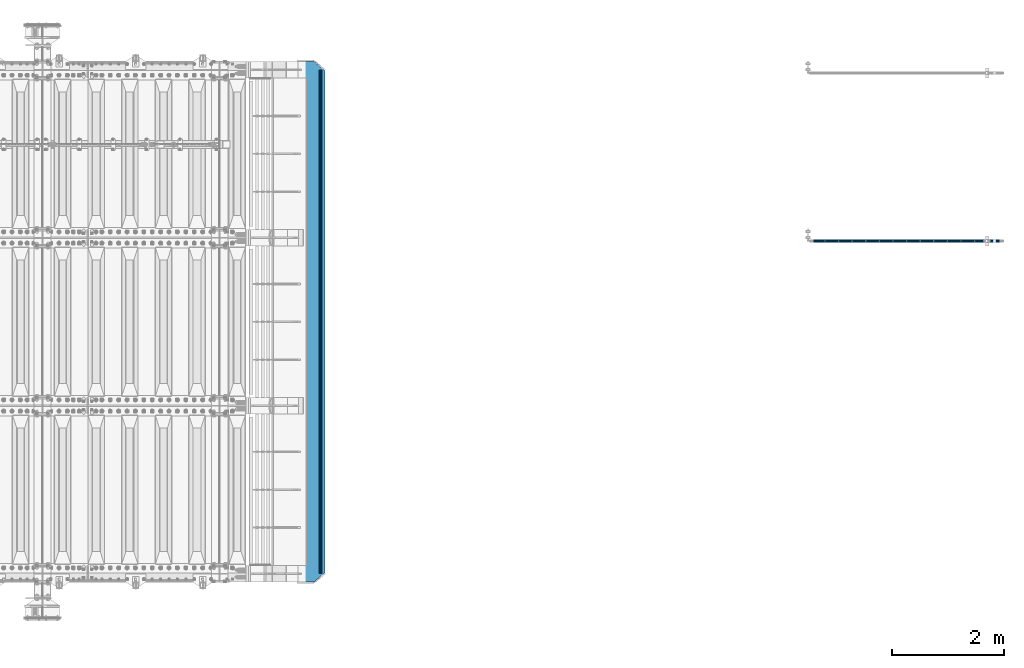
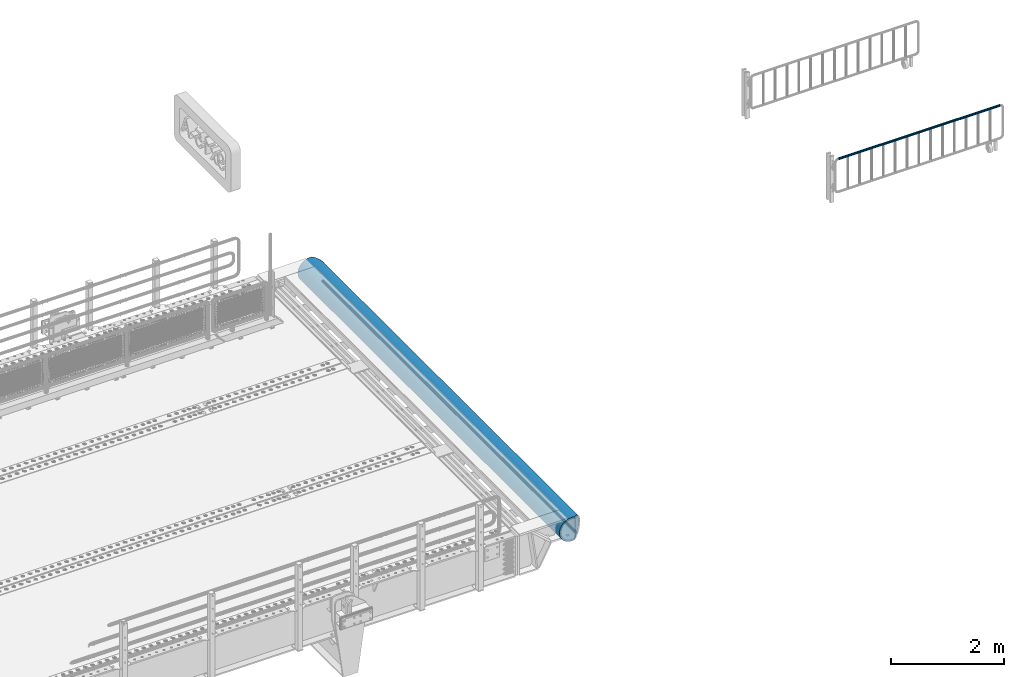
# One storey, part 119 of 219: 3 beams.
"""IFC2X3 building model written with IfcOpenShell, lengths in millimetres."""

from ifc_helpers import new_model, si_unit, frame, origin_with_axes, place, context, subcontext, project, spatial, faceted_brep, material, type_object, element, save


model = new_model("IFC2X3")

# Units and contexts
model_context = context("Model", 3, precision=1e-05, world=origin_with_axes())
body_context = subcontext(model_context, "Body", "Model", "MODEL_VIEW")
ifc_project = project(units=[si_unit("LENGTHUNIT", "METRE", prefix="MILLI"), si_unit("AREAUNIT", "SQUARE_METRE"), si_unit("VOLUMEUNIT", "CUBIC_METRE"), si_unit("MASSUNIT", "GRAM", prefix="KILO"), si_unit("TIMEUNIT", "SECOND"), si_unit("PLANEANGLEUNIT", "RADIAN"), si_unit("SOLIDANGLEUNIT", "STERADIAN"), si_unit("THERMODYNAMICTEMPERATUREUNIT", "DEGREE_CELSIUS"), si_unit("LUMINOUSINTENSITYUNIT", "LUMEN")], contexts=[model_context])

# Site, building, storey
site_placement = place(None, origin_with_axes())
site = spatial("IfcSite", under=ifc_project, at=site_placement, CompositionType="ELEMENT")
building_placement = place(site_placement, origin_with_axes())
building = spatial("IfcBuilding", under=site, at=building_placement, Name="Standard", CompositionType="ELEMENT")
storey_placement = place(building_placement, origin_with_axes())
storey = spatial("IfcBuildingStorey", under=building, at=storey_placement, Name="Undefined", CompositionType="ELEMENT", Elevation=0.0)

# Beams
ifc_material_1 = material()
beam_type_1 = type_object("IfcBeamType", PredefinedType="NOTDEFINED")
beam_1_placement = place(storey_placement, frame((24165.2460172356, 29941.8539999962, 935.350006544462), z_axis=(0.0, 0.0, 1.0), x_axis=(1.0, 0.0, 0.0)))
element("IfcBeam", 1, at=beam_1_placement, inside=storey, type_object=beam_type_1, material=ifc_material_1, context=body_context, shape_type="Brep", body=[
    faceted_brep([(0.0, -20.5499999999993, 0.0), (0.0, -17.7968220477705, 10.2750000000015), (3317.7, -17.7968220477705, 10.275), (3317.7, -20.5499999999993, 0.0), (0.0, -10.2750000000015, 17.7968220477705), (3317.7, -10.2750000000015, 17.7968220477702), (0.0, 0.0, 20.5499999999993), (3317.7, 0.0, 20.55), (0.0, 10.2750000000015, 17.7968220477705), (3317.7, 10.2750000000015, 17.7968220477702), (0.0, 17.7968220477705, 10.2750000000015), (3317.7, 17.7968220477705, 10.275), (0.0, 20.5499999999993, 0.0), (3317.7, 20.5499999999993, 0.0), (0.0, 17.7968220477705, -10.2750000000015), (3317.7, 17.7968220477705, -10.275), (0.0, 10.2750000000015, -17.7968220477705), (3317.7, 10.2750000000015, -17.7968220477702), (0.0, 0.0, -20.5499999999993), (3317.7, 0.0, -20.55), (0.0, -10.2750000000015, -17.7968220477705), (3317.7, -10.2750000000015, -17.7968220477702), (0.0, -17.7968220477705, -10.2750000000015), (3317.7, -17.7968220477705, -10.275), (0.0, -24.1500000000015, 0.0), (0.0, -20.9145135013932, -12.0750000000007), (3317.7, -20.9145135013932, -12.075), (3317.7, -24.1500000000015, 0.0), (0.0, -12.0750000000007, -20.9145135013932), (3317.7, -12.0750000000007, -20.9145135013943), (0.0, 0.0, -24.1500000000015), (3317.7, 0.0, -24.15), (0.0, 12.0750000000007, -20.9145135013932), (3317.7, 12.0750000000007, -20.9145135013941), (0.0, 20.9145135013932, -12.0750000000007), (3317.7, 20.9145135013932, -12.075), (0.0, 24.1500000000015, 0.0), (3317.7, 24.1500000000015, 0.0), (0.0, 20.9145135013932, 12.0750000000007), (3317.7, 20.9145135013932, 12.075), (0.0, 12.0750000000007, 20.9145135013932), (3317.7, 12.0750000000007, 20.9145135013941), (0.0, 0.0, 24.1500000000015), (3317.7, 0.0, 24.15), (0.0, -12.0750000000007, 20.9145135013932), (3317.7, -12.0750000000007, 20.9145135013941), (0.0, -20.9145135013932, 12.0750000000007), (3317.7, -20.9145135013932, 12.075)], [[[0, 1, 2, 3]], [[1, 4, 5, 2]], [[4, 6, 7, 5]], [[6, 8, 9, 7]], [[8, 10, 11, 9]], [[10, 12, 13, 11]], [[12, 14, 15, 13]], [[14, 16, 17, 15]], [[16, 18, 19, 17]], [[18, 20, 21, 19]], [[20, 22, 23, 21]], [[22, 0, 3, 23]], [[24, 25, 26, 27]], [[25, 28, 29, 26]], [[28, 30, 31, 29]], [[30, 32, 33, 31]], [[32, 34, 35, 33]], [[34, 36, 37, 35]], [[36, 38, 39, 37]], [[38, 40, 41, 39]], [[40, 42, 43, 41]], [[42, 44, 45, 43]], [[44, 46, 47, 45]], [[46, 24, 27, 47]], [[29, 31, 33, 35, 37, 39, 41, 43, 45, 47, 27, 26], [5, 7, 9, 11, 13, 15, 17, 19, 21, 23, 3, 2]], [[46, 44, 42, 40, 38, 36, 34, 32, 30, 28, 25, 24], [22, 20, 18, 16, 14, 12, 10, 8, 6, 4, 1, 0]]]),
])
ifc_material_2 = material(Name="STEEL/S355N")
beam_type_2 = type_object("IfcBeamType", PredefinedType="NOTDEFINED")
beam_2_placement = place(storey_placement, frame((15182.9988298906, 33150.0, -254.000000000001), z_axis=(0.0, 0.0, 1.0), x_axis=(0.0, -1.0, 0.0)))
element("IfcBeam", 2, at=beam_2_placement, inside=storey, type_object=beam_type_2, material=ifc_material_2, context=body_context, shape_type="Brep", body=[
    faceted_brep([(6132.32233047034, -17.6739734137791, -220.609028125962), (6132.32233047034, -17.6739734137791, -252.609028125963), (6126.90301168722, -9.56338969324315, -253.247344908113), (6126.90301168722, -9.56338969324315, -221.247344908112), (6140.43291419087, -23.0932921968979, -220.182518487904), (6140.43291419087, -23.0932921968979, -252.182518487904), (6150.0, -24.9963038841161, -220.032748220013), (6150.0, -24.9963038841161, -252.032748220013), (6159.56708580913, -23.0932921968979, -220.182518487904), (6159.56708580913, -23.0932921968979, -252.182518487904), (6167.67766952966, -17.6739734137791, -220.609028125962), (6167.67766952966, -17.6739734137791, -252.609028125963), (6173.09698831278, -9.56338969324315, -221.247344908112), (6173.09698831278, -9.56338969324315, -253.247344908113), (6175.0, 0.0, -222.0), (6175.0, 0.0, -254.0), (6173.09698831278, 9.57078192501103, -221.246763126855), (6173.09698831278, 9.57078192501103, -253.246763126856), (6167.67766952966, 17.681365645547, -220.608446344705), (6167.67766952966, 17.681365645547, -252.608446344706), (6159.56708580913, 23.1006844286658, -220.181936706647), (6159.56708580913, 23.1006844286658, -252.181936706648), (6150.0, 25.0036961158839, -220.032166438756), (6150.0, 25.0036961158839, -252.032166438756), (6140.43291419087, 23.1006844286658, -220.181936706647), (6140.43291419087, 23.1006844286658, -252.181936706648), (6132.32233047034, 17.681365645547, -220.608446344705), (6132.32233047034, 17.681365645547, -252.608446344706), (6126.90301168722, 9.57078192501103, -221.246763126855), (6126.90301168722, 9.57078192501103, -253.246763126856), (6125.0, 0.0, -222.0), (6125.0, 0.0, -254.0), (4632.32233047034, -17.6739734137755, -220.609028125963), (4632.32233047034, -17.6739734137755, -252.609028125962), (4626.90301168722, -9.56338969323951, -253.247344908112), (4626.90301168722, -9.56338969323951, -221.247344908113), (4640.43291419087, -23.0932921968943, -220.182518487905), (4640.43291419087, -23.0932921968943, -252.182518487904), (4650.0, -24.9963038841124, -220.032748220013), (4650.0, -24.9963038841124, -252.032748220013), (4659.56708580913, -23.0932921968943, -220.182518487905), (4659.56708580913, -23.0932921968943, -252.182518487904), (4667.67766952966, -17.6739734137755, -220.609028125963), (4667.67766952966, -17.6739734137755, -252.609028125962), (4673.09698831278, -9.56338969323951, -221.247344908113), (4673.09698831278, -9.56338969323951, -253.247344908112), (4675.0, 0.0, -222.0), (4675.0, 0.0, -254.0), (4673.09698831278, 9.57078192501467, -221.246763126855), (4673.09698831278, 9.57078192501467, -253.246763126856), (4667.67766952966, 17.6813656455506, -220.608446344705), (4667.67766952966, 17.6813656455506, -252.608446344705), (4659.56708580913, 23.1006844286694, -220.181936706647), (4659.56708580913, 23.1006844286694, -252.181936706647), (4650.0, 25.0036961158876, -220.032166438756), (4650.0, 25.0036961158876, -252.032166438756), (4640.43291419087, 23.1006844286694, -220.181936706647), (4640.43291419087, 23.1006844286694, -252.181936706647), (4632.32233047034, 17.6813656455506, -220.608446344705), (4632.32233047034, 17.6813656455506, -252.608446344705), (4626.90301168722, 9.57078192501467, -221.246763126855), (4626.90301168722, 9.57078192501467, -253.246763126856), (4625.0, 0.0, -222.0), (4625.0, 0.0, -254.0), (3132.32233047034, -17.6776695296594, -220.608737235334), (3132.32233047034, -17.6776695296594, -252.608737235334), (3126.90301168722, -9.56708580912346, -253.247054017484), (3126.90301168722, -9.56708580912346, -221.247054017484), (3140.43291419087, -23.0969883127782, -220.182227597276), (3140.43291419087, -23.0969883127782, -252.182227597276), (3150.0, -24.9999999999964, -220.032457329385), (3150.0, -24.9999999999964, -252.032457329385), (3159.56708580913, -23.0969883127782, -220.182227597276), (3159.56708580913, -23.0969883127782, -252.182227597276), (3167.67766952966, -17.6776695296594, -220.608737235334), (3167.67766952966, -17.6776695296594, -252.608737235334), (3173.09698831278, -9.56708580912346, -221.247054017484), (3173.09698831278, -9.56708580912346, -253.247054017484), (3175.0, 0.0, -222.0), (3175.0, 0.0, -254.0), (3173.09698831278, 9.56708580913073, -221.247054017484), (3173.09698831278, 9.56708580913073, -253.247054017484), (3167.67766952966, 17.6776695296667, -220.608737235334), (3167.67766952966, 17.6776695296667, -252.608737235334), (3159.56708580913, 23.0969883127855, -220.182227597275), (3159.56708580913, 23.0969883127855, -252.182227597276), (3150.0, 25.0000000000036, -220.032457329384), (3150.0, 25.0000000000036, -252.032457329384), (3140.43291419087, 23.0969883127855, -220.182227597275), (3140.43291419087, 23.0969883127855, -252.182227597276), (3132.32233047034, 17.6776695296667, -220.608737235334), (3132.32233047034, 17.6776695296667, -252.608737235334), (3126.90301168722, 9.56708580913073, -221.247054017484), (3126.90301168722, 9.56708580913073, -253.247054017484), (3125.0, 0.0, -222.0), (3125.0, 0.0, -254.0), (1632.32233047034, -17.6776695296594, -220.608737235334), (1632.32233047034, -17.6776695296594, -252.608737235334), (1626.90301168722, -9.56708580912346, -253.247054017484), (1626.90301168722, -9.56708580912346, -221.247054017484), (1640.43291419087, -23.0969883127782, -220.182227597276), (1640.43291419087, -23.0969883127782, -252.182227597276), (1650.0, -24.9999999999964, -220.032457329385), (1650.0, -24.9999999999964, -252.032457329385), (1659.56708580913, -23.0969883127782, -220.182227597276), (1659.56708580913, -23.0969883127782, -252.182227597276), (1667.67766952966, -17.6776695296594, -220.608737235334), (1667.67766952966, -17.6776695296594, -252.608737235334), (1673.09698831278, -9.56708580912346, -221.247054017484), (1673.09698831278, -9.56708580912346, -253.247054017484), (1675.0, 0.0, -222.0), (1675.0, 0.0, -254.0), (1673.09698831278, 9.56708580913073, -221.247054017483), (1673.09698831278, 9.56708580913073, -253.247054017484), (1667.67766952966, 17.6776695296667, -220.608737235333), (1667.67766952966, 17.6776695296667, -252.608737235334), (1659.56708580913, 23.0969883127855, -220.182227597275), (1659.56708580913, 23.0969883127855, -252.182227597276), (1650.0, 25.0000000000036, -220.032457329384), (1650.0, 25.0000000000036, -252.032457329385), (1640.43291419087, 23.0969883127855, -220.182227597275), (1640.43291419087, 23.0969883127855, -252.182227597276), (1632.32233047034, 17.6776695296667, -220.608737235333), (1632.32233047034, 17.6776695296667, -252.608737235334), (1626.90301168722, 9.56708580913073, -221.247054017483), (1626.90301168722, 9.56708580913073, -253.247054017484), (1625.0, 0.0, -222.0), (1625.0, 0.0, -254.0), (132.322330470335, -17.6776695296594, -220.608737235334), (132.322330470335, -17.6776695296594, -252.608737235334), (126.903011687216, -9.56708580912346, -253.247054017484), (126.903011687216, -9.56708580912346, -221.247054017484), (140.432914190875, -23.0969883127782, -220.182227597276), (140.432914190875, -23.0969883127782, -252.182227597276), (150.0, -24.9999999999964, -220.032457329385), (150.0, -24.9999999999964, -252.032457329385), (159.567085809125, -23.0969883127782, -220.182227597276), (159.567085809125, -23.0969883127782, -252.182227597276), (167.677669529665, -17.6776695296594, -220.608737235334), (167.677669529665, -17.6776695296594, -252.608737235334), (173.096988312784, -9.56708580912346, -221.247054017484), (173.096988312784, -9.56708580912346, -253.247054017484), (175.0, 0.0, -222.0), (175.0, 0.0, -254.0), (173.096988312784, 9.56708580913073, -221.247054017484), (173.096988312784, 9.56708580913073, -253.247054017484), (167.677669529665, 17.6776695296667, -220.608737235334), (167.677669529665, 17.6776695296667, -252.608737235334), (159.567085809125, 23.0969883127855, -220.182227597276), (159.567085809125, 23.0969883127855, -252.182227597276), (150.0, 25.0000000000036, -220.032457329384), (150.0, 25.0000000000036, -252.032457329385), (140.432914190875, 23.0969883127855, -220.182227597276), (140.432914190875, 23.0969883127855, -252.182227597276), (132.322330470335, 17.6776695296667, -220.608737235334), (132.322330470335, 17.6776695296667, -252.608737235334), (126.903011687216, 9.56708580913073, -221.247054017484), (126.903011687216, 9.56708580913073, -253.247054017484), (125.0, 0.0, -222.0), (125.0, 0.0, -254.0), (0.0, -34.7284512389306, -219.266811612121), (0.0, -68.601772751239, -211.134546617524), (9300.0, -68.601772751239, -211.134546617524), (9300.0, -34.7284512389306, -219.266811612121), (0.0, -100.785890942179, -197.803448369818), (9300.0, -100.785890942179, -197.803448369818), (0.0, -130.488326008928, -179.601772751238), (9300.0, -130.488326008928, -179.601772751238), (0.0, -156.977705423413, -156.977705423414), (9300.0, -156.977705423413, -156.977705423414), (0.0, -179.601772751239, -130.488326008929), (9300.0, -179.601772751239, -130.488326008929), (0.0, -197.803448369817, -100.785890942179), (9300.0, -197.803448369817, -100.785890942179), (0.0, -211.134546617524, -68.6017727512383), (9300.0, -211.134546617524, -68.6017727512383), (0.0, -219.26681161212, -34.7284512389313), (9300.0, -219.26681161212, -34.7284512389313), (0.0, -222.0, 0.0), (9300.0, -222.0, 0.0), (0.0, -219.26681161212, 34.7284512389313), (9300.0, -219.26681161212, 34.7284512389313), (0.0, -211.134546617524, 68.6017727512384), (9300.0, -211.134546617524, 68.6017727512384), (0.0, -197.803448369817, 100.785890942179), (9300.0, -197.803448369817, 100.785890942179), (0.0, -179.601772751239, 130.488326008929), (9300.0, -179.601772751239, 130.488326008929), (0.0, -156.977705423413, 156.977705423414), (9300.0, -156.977705423413, 156.977705423414), (0.0, -130.488326008928, 179.601772751238), (9300.0, -130.488326008928, 179.601772751238), (0.0, -100.785890942179, 197.803448369818), (9300.0, -100.785890942179, 197.803448369818), (0.0, -68.601772751239, 211.134546617524), (9300.0, -68.601772751239, 211.134546617524), (0.0, -34.7284512389306, 219.266811612121), (9300.0, -34.7284512389306, 219.266811612121), (0.0, 0.0, 222.0), (9300.0, 0.0, 222.0), (0.0, 34.7284512389306, 219.266811612121), (9300.0, 34.7284512389306, 219.266811612121), (9287.59163509752, 68.601772751239, 211.134546617524), (9300.0, 54.0036961158876, 214.639234741096), (0.0, 54.0000000000036, 214.64012210001), (12.4115067427192, 68.601772751239, 211.134546617524), (9260.235135159, 100.785890942179, 197.803448369818), (39.7680069938142, 100.785890942179, 197.803448369818), (9234.98806583565, 130.488326008928, 179.601772751238), (65.0150766056322, 130.488326008928, 179.601772751238), (9212.47209376443, 156.977705423413, 156.977705423414), (87.5310489341136, 156.977705423413, 156.977705423414), (9193.24163690396, 179.601772751239, 130.488326008929), (106.761506014285, 179.601772751239, 130.488326008929), (9177.77021292439, 197.803448369817, 100.785890942179), (122.232930170641, 197.803448369817, 100.785890942179), (9166.43877963079, 211.134546617524, 68.6017727512383), (133.564363593716, 211.134546617524, 68.6017727512383), (9159.52635451773, 219.26681161212, 34.7284512389312), (140.476788785745, 219.26681161212, 34.7284512389312), (9157.20314443251, 222.0, -2.8421709430404e-14), (142.799998897506, 222.0, -2.8421709430404e-14), (9159.52635451773, 219.26681161212, -34.7284512389313), (140.476788785745, 219.26681161212, -34.7284512389313), (9166.43877963079, 211.134546617524, -68.6017727512383), (133.564363593716, 211.134546617524, -68.6017727512383), (9177.77021292439, 197.803448369817, -100.785890942179), (122.232930170641, 197.803448369817, -100.785890942179), (9193.24163690396, 179.601772751239, -130.488326008929), (106.761506014285, 179.601772751239, -130.488326008929), (9212.47209376443, 156.977705423413, -156.977705423414), (87.5310489341136, 156.977705423413, -156.977705423414), (9234.98806583565, 130.488326008928, -179.601772751238), (65.0150766056322, 130.488326008928, -179.601772751238), (9260.235135159, 100.785890942179, -197.803448369818), (39.7680069938142, 100.785890942179, -197.803448369818), (9287.59163509752, 68.601772751239, -211.134546617524), (12.4115067427192, 68.601772751239, -211.134546617524), (0.0, 34.7284512389306, -219.266811612121), (9300.0, 34.7284512389306, -219.266811612121), (9300.0, 54.0036961158876, -214.639234741096), (0.0, 54.0000000000036, -214.64012210001), (9140.57004288285, 241.568355138968, -78.4903165712366), (9153.53483593048, 226.315657143845, -115.313586933845), (146.468307441464, 226.315657143845, -115.313586933845), (159.433100637223, 241.568355138968, -78.4903165712366), (9171.23637507828, 205.490316571237, -149.297454082288), (128.766768091402, 205.490316571237, -149.297454082288), (9193.2387896844, 179.605122421382, -179.605122421383), (106.764353233899, 179.605122421382, -179.605122421383), (9219.00030727939, 149.297454082289, -205.490316571237), (81.0028353445596, 149.297454082289, -205.490316571237), (9247.88659380251, 115.313586933846, -226.315657143845), (52.1165484913945, 115.313586933846, -226.315657143845), (9279.18637301146, 78.4903165712367, -241.568355138969), (20.8167689248294, 78.4903165712367, -241.568355138969), (9300.0, 54.0036961158876, -247.447072591955), (9300.0, 39.734354120219, -250.872838511165), (0.0, 39.734354120219, -250.872838511165), (0.0, 54.0000000000036, -247.44795995087), (0.0, 0.0, -222.0), (0.0, 0.0, -254.0), (0.0, -39.734354120219, -250.872838511165), (0.0, -78.4903165712367, -241.568355138969), (0.0, -115.313586933846, -226.315657143845), (0.0, -149.297454082289, -205.490316571237), (0.0, -179.605122421382, -179.605122421383), (0.0, -205.490316571237, -149.297454082288), (0.0, -226.315657143845, -115.313586933845), (0.0, -241.568355138968, -78.4903165712367), (0.0, -250.872838511164, -39.7343541202187), (0.0, -254.0, 0.0), (0.0, -250.872838511164, 39.7343541202187), (0.0, -241.568355138968, 78.4903165712366), (0.0, -226.315657143845, 115.313586933845), (0.0, -205.490316571237, 149.297454082288), (0.0, -179.605122421382, 179.605122421383), (0.0, -149.297454082289, 205.490316571237), (0.0, -115.313586933846, 226.315657143845), (0.0, -78.4903165712367, 241.568355138969), (0.0, -39.734354120219, 250.872838511165), (0.0, 0.0, 254.0), (0.0, 39.734354120219, 250.872838511165), (0.0, 54.0000000000036, 247.44795995087), (9300.0, -39.734354120219, -250.872838511165), (9300.0, -78.4903165712367, -241.568355138969), (9300.0, -115.313586933846, -226.315657143845), (9300.0, -149.297454082289, -205.490316571237), (9300.0, -179.605122421382, -179.605122421383), (9300.0, -205.490316571237, -149.297454082288), (9300.0, -226.315657143845, -115.313586933845), (9300.0, -241.568355138968, -78.4903165712367), (9300.0, -250.872838511164, -39.7343541202187), (9300.0, -254.0, 0.0), (9300.0, -250.872838511164, 39.7343541202187), (9300.0, -241.568355138968, 78.4903165712366), (9300.0, -226.315657143845, 115.313586933845), (9300.0, -205.490316571237, 149.297454082288), (9300.0, -179.605122421382, 179.605122421383), (9300.0, -149.297454082289, 205.490316571237), (9300.0, -115.313586933846, 226.315657143845), (9300.0, -78.4903165712367, 241.568355138969), (9300.0, -39.734354120219, 250.872838511165), (9300.0, 0.0, 254.0), (9300.0, 39.734354120219, 250.872838511165), (9300.0, 54.0036961158876, 247.447072591955), (9279.18637301146, 78.4903165712367, 241.568355138969), (20.8167689248294, 78.4903165712367, 241.568355138969), (9247.88659380251, 115.313586933846, 226.315657143845), (52.1165484913945, 115.313586933846, 226.315657143845), (9219.00030727939, 149.297454082289, 205.490316571237), (81.0028353445596, 149.297454082289, 205.490316571237), (9193.2387896844, 179.605122421382, 179.605122421383), (106.764353233899, 179.605122421382, 179.605122421383), (9171.23637507828, 205.490316571237, 149.297454082288), (128.766768091402, 205.490316571237, 149.297454082288), (9153.53483593048, 226.315657143845, 115.313586933845), (146.468307441464, 226.315657143845, 115.313586933845), (9140.57004288285, 241.568355138968, 78.4903165712367), (159.433100637223, 241.568355138968, 78.4903165712367), (9129.99999983242, 254.003700142275, 0.0), (9132.66123216791, 250.872838511164, -39.7343541202186), (167.34191144252, 250.872838511164, -39.7343541202186), (170.000001295222, 254.000003067895, 5.6843418860808e-14), (9132.66123216791, 250.872838511164, 39.7343541202187), (167.34191144252, 250.872838511164, 39.7343541202187), (9300.0, 0.0, -254.0), (9300.0, 0.0, -222.0), (7675.0, 0.0, -222.0), (7673.09698831278, -9.56338969324315, -221.247344908112), (7667.67766952966, -17.6739734137791, -220.609028125962), (7659.56708580913, -23.0932921968979, -220.182518487904), (7650.0, -24.9963038841161, -220.032748220013), (7640.43291419087, -23.0932921968979, -220.182518487904), (7632.32233047034, -17.6739734137791, -220.609028125962), (7626.90301168722, -9.56338969324315, -221.247344908112), (7625.0, 0.0, -222.0), (9175.0, 0.0, -222.0), (9173.09698831278, -9.56338969324679, -221.247344908112), (9167.67766952966, -17.6739734137827, -220.609028125962), (9159.56708580913, -23.0932921969015, -220.182518487904), (9150.0, -24.9963038841197, -220.032748220012), (9140.43291419087, -23.0932921969015, -220.182518487904), (9132.32233047034, -17.6739734137827, -220.609028125962), (9126.90301168722, -9.56338969324679, -221.247344908112), (9125.0, 0.0, -222.0), (9167.67766952966, 17.6813656455433, -220.608446344706), (9173.09698831278, 9.5707819250074, -221.246763126856), (7626.90301168722, 9.57078192501103, -221.246763126856), (7632.32233047034, 17.681365645547, -220.608446344706), (7640.43291419087, 23.1006844286658, -220.181936706647), (7650.0, 25.0036961158839, -220.032166438756), (7659.56708580913, 23.1006844286658, -220.181936706647), (7667.67766952966, 17.681365645547, -220.608446344706), (7673.09698831278, 9.57078192501103, -221.246763126856), (9126.90301168722, 9.5707819250074, -221.246763126856), (9132.32233047034, 17.6813656455433, -220.608446344706), (9140.43291419087, 23.1006844286621, -220.181936706648), (9150.0, 25.0036961158803, -220.032166438756), (9159.56708580913, 23.1006844286621, -220.181936706648), (7673.09698831278, 9.57078192501103, -253.246763126856), (7675.0, 0.0, -254.0), (7667.67766952966, 17.681365645547, -252.608446344706), (7659.56708580913, 23.1006844286658, -252.181936706648), (7650.0, 25.0036961158839, -252.032166438757), (7640.43291419087, 23.1006844286658, -252.181936706648), (7632.32233047034, 17.681365645547, -252.608446344706), (7626.90301168722, 9.57078192501103, -253.246763126856), (7625.0, 0.0, -254.0), (7626.90301168722, -9.56338969324315, -253.247344908112), (7632.32233047034, -17.6739734137791, -252.609028125962), (7640.43291419087, -23.0932921968979, -252.182518487903), (7650.0, -24.9963038841161, -252.032748220012), (7659.56708580913, -23.0932921968979, -252.182518487903), (7667.67766952966, -17.6739734137791, -252.609028125962), (7673.09698831278, -9.56338969324315, -253.247344908112), (9132.32233047034, -17.6739734137827, -252.609028125962), (9140.43291419087, -23.0932921969015, -252.182518487903), (9150.0, -24.9963038841197, -252.032748220012), (9159.56708580913, -23.0932921969015, -252.182518487903), (9167.67766952966, -17.6739734137827, -252.609028125962), (9173.09698831278, -9.56338969324679, -253.247344908112), (9175.0, 0.0, -254.0), (9125.0, 0.0, -254.0), (9126.90301168722, -9.56338969324679, -253.247344908112), (9132.32233047034, 17.6813656455433, -252.608446344706), (9126.90301168722, 9.5707819250074, -253.246763126856), (9173.09698831278, 9.5707819250074, -253.246763126856), (9167.67766952966, 17.6813656455433, -252.608446344706), (9159.56708580913, 23.1006844286621, -252.181936706648), (9150.0, 25.0036961158803, -252.032166438757), (9140.43291419087, 23.1006844286621, -252.181936706648)], [[[0, 1, 2, 3]], [[4, 5, 1, 0]], [[6, 7, 5, 4]], [[8, 9, 7, 6]], [[10, 11, 9, 8]], [[12, 13, 11, 10]], [[14, 15, 13, 12]], [[16, 17, 15, 14]], [[18, 19, 17, 16]], [[20, 21, 19, 18]], [[22, 23, 21, 20]], [[24, 25, 23, 22]], [[26, 27, 25, 24]], [[28, 29, 27, 26]], [[30, 31, 29, 28]], [[3, 2, 31, 30]], [[32, 33, 34, 35]], [[36, 37, 33, 32]], [[38, 39, 37, 36]], [[40, 41, 39, 38]], [[42, 43, 41, 40]], [[44, 45, 43, 42]], [[46, 47, 45, 44]], [[48, 49, 47, 46]], [[50, 51, 49, 48]], [[52, 53, 51, 50]], [[54, 55, 53, 52]], [[56, 57, 55, 54]], [[58, 59, 57, 56]], [[60, 61, 59, 58]], [[62, 63, 61, 60]], [[35, 34, 63, 62]], [[64, 65, 66, 67]], [[68, 69, 65, 64]], [[70, 71, 69, 68]], [[72, 73, 71, 70]], [[74, 75, 73, 72]], [[76, 77, 75, 74]], [[78, 79, 77, 76]], [[80, 81, 79, 78]], [[82, 83, 81, 80]], [[84, 85, 83, 82]], [[86, 87, 85, 84]], [[88, 89, 87, 86]], [[90, 91, 89, 88]], [[92, 93, 91, 90]], [[94, 95, 93, 92]], [[67, 66, 95, 94]], [[96, 97, 98, 99]], [[100, 101, 97, 96]], [[102, 103, 101, 100]], [[104, 105, 103, 102]], [[106, 107, 105, 104]], [[108, 109, 107, 106]], [[110, 111, 109, 108]], [[112, 113, 111, 110]], [[114, 115, 113, 112]], [[116, 117, 115, 114]], [[118, 119, 117, 116]], [[120, 121, 119, 118]], [[122, 123, 121, 120]], [[124, 125, 123, 122]], [[126, 127, 125, 124]], [[99, 98, 127, 126]], [[128, 129, 130, 131]], [[132, 133, 129, 128]], [[134, 135, 133, 132]], [[136, 137, 135, 134]], [[138, 139, 137, 136]], [[140, 141, 139, 138]], [[142, 143, 141, 140]], [[144, 145, 143, 142]], [[146, 147, 145, 144]], [[148, 149, 147, 146]], [[150, 151, 149, 148]], [[152, 153, 151, 150]], [[154, 155, 153, 152]], [[156, 157, 155, 154]], [[158, 159, 157, 156]], [[131, 130, 159, 158]], [[160, 161, 162, 163]], [[161, 164, 165, 162]], [[164, 166, 167, 165]], [[166, 168, 169, 167]], [[168, 170, 171, 169]], [[170, 172, 173, 171]], [[172, 174, 175, 173]], [[174, 176, 177, 175]], [[176, 178, 179, 177]], [[178, 180, 181, 179]], [[180, 182, 183, 181]], [[182, 184, 185, 183]], [[184, 186, 187, 185]], [[186, 188, 189, 187]], [[188, 190, 191, 189]], [[190, 192, 193, 191]], [[192, 194, 195, 193]], [[194, 196, 197, 195]], [[196, 198, 199, 197]], [[198, 200, 201, 199]], [[202, 203, 201, 200, 204, 205]], [[206, 202, 205, 207]], [[208, 206, 207, 209]], [[210, 208, 209, 211]], [[212, 210, 211, 213]], [[214, 212, 213, 215]], [[216, 214, 215, 217]], [[218, 216, 217, 219]], [[220, 218, 219, 221]], [[222, 220, 221, 223]], [[224, 222, 223, 225]], [[226, 224, 225, 227]], [[228, 226, 227, 229]], [[230, 228, 229, 231]], [[232, 230, 231, 233]], [[234, 232, 233, 235]], [[236, 234, 235, 237]], [[238, 239, 240, 236, 237, 241]], [[242, 243, 244, 245]], [[243, 246, 247, 244]], [[246, 248, 249, 247]], [[248, 250, 251, 249]], [[250, 252, 253, 251]], [[252, 254, 255, 253]], [[254, 256, 257, 258, 259, 255]], [[200, 198, 196, 194, 192, 190, 188, 186, 184, 182, 180, 178, 176, 174, 172, 170, 168, 166, 164, 161, 160, 260, 238, 241, 259, 258, 261, 262, 263, 264, 265, 266, 267, 268, 269, 270, 271, 272, 273, 274, 275, 276, 277, 278, 279, 280, 281, 282, 283, 204]], [[263, 262, 284, 285]], [[264, 263, 285, 286]], [[265, 264, 286, 287]], [[266, 265, 287, 288]], [[267, 266, 288, 289]], [[268, 267, 289, 290]], [[269, 268, 290, 291]], [[270, 269, 291, 292]], [[271, 270, 292, 293]], [[272, 271, 293, 294]], [[273, 272, 294, 295]], [[274, 273, 295, 296]], [[275, 274, 296, 297]], [[276, 275, 297, 298]], [[277, 276, 298, 299]], [[278, 277, 299, 300]], [[279, 278, 300, 301]], [[280, 279, 301, 302]], [[281, 280, 302, 303]], [[282, 281, 303, 304]], [[282, 304, 305, 306, 307, 283]], [[306, 308, 309, 307]], [[308, 310, 311, 309]], [[310, 312, 313, 311]], [[312, 314, 315, 313]], [[314, 316, 317, 315]], [[316, 318, 319, 317]], [[320, 321, 322, 323]], [[324, 320, 323, 325]], [[318, 324, 325, 319]], [[323, 322, 245, 244, 247, 249, 251, 253, 255, 259, 241, 237, 235, 233, 231, 229, 227, 225, 223, 221, 219, 217, 215, 213, 211, 209, 207, 205, 204, 283, 307, 309, 311, 313, 315, 317, 319, 325]], [[321, 242, 245, 322]], [[320, 324, 318, 316, 314, 312, 310, 308, 306, 305, 203, 202, 206, 208, 210, 212, 214, 216, 218, 220, 222, 224, 226, 228, 230, 232, 234, 236, 240, 256, 254, 252, 250, 248, 246, 243, 242, 321]], [[304, 303, 302, 301, 300, 299, 298, 297, 296, 295, 294, 293, 292, 291, 290, 289, 288, 287, 286, 285, 284, 326, 257, 256, 240, 239, 327, 163, 162, 165, 167, 169, 171, 173, 175, 177, 179, 181, 183, 185, 187, 189, 191, 193, 195, 197, 199, 201, 203, 305]], [[328, 329, 330, 331, 332, 333, 334, 335, 336, 14, 12, 10, 8, 6, 4, 0, 3, 30, 46, 44, 42, 40, 38, 36, 32, 35, 62, 78, 76, 74, 72, 70, 68, 64, 67, 94, 110, 108, 106, 104, 102, 100, 96, 99, 126, 142, 140, 138, 136, 134, 132, 128, 131, 158, 260, 160, 163, 327, 337, 338, 339, 340, 341, 342, 343, 344, 345]], [[346, 347, 337, 327, 239, 238, 260, 158, 156, 154, 152, 150, 148, 146, 144, 142, 126, 124, 122, 120, 118, 116, 114, 112, 110, 94, 92, 90, 88, 86, 84, 82, 80, 78, 62, 60, 58, 56, 54, 52, 50, 48, 46, 30, 28, 26, 24, 22, 20, 18, 16, 14, 336, 348, 349, 350, 351, 352, 353, 354, 328, 345, 355, 356, 357, 358, 359]], [[354, 360, 361, 328]], [[353, 362, 360, 354]], [[352, 363, 362, 353]], [[351, 364, 363, 352]], [[350, 365, 364, 351]], [[349, 366, 365, 350]], [[348, 367, 366, 349]], [[336, 368, 367, 348]], [[335, 369, 368, 336]], [[334, 370, 369, 335]], [[333, 371, 370, 334]], [[332, 372, 371, 333]], [[331, 373, 372, 332]], [[330, 374, 373, 331]], [[329, 375, 374, 330]], [[328, 361, 375, 329]], [[376, 377, 378, 379, 380, 381, 382, 326, 284, 262, 261, 159, 130, 129, 133, 135, 137, 139, 141, 143, 127, 98, 97, 101, 103, 105, 107, 109, 111, 95, 66, 65, 69, 71, 73, 75, 77, 79, 63, 34, 33, 37, 39, 41, 43, 45, 47, 31, 2, 1, 5, 7, 9, 11, 13, 15, 368, 369, 370, 371, 372, 373, 374, 375, 361, 383, 384]], [[385, 386, 383, 361, 360, 362, 363, 364, 365, 366, 367, 368, 15, 17, 19, 21, 23, 25, 27, 29, 31, 47, 49, 51, 53, 55, 57, 59, 61, 63, 79, 81, 83, 85, 87, 89, 91, 93, 95, 111, 113, 115, 117, 119, 121, 123, 125, 127, 143, 145, 147, 149, 151, 153, 155, 157, 159, 261, 258, 257, 326, 382, 387, 388, 389, 390, 391]], [[358, 390, 389, 359]], [[357, 391, 390, 358]], [[356, 385, 391, 357]], [[355, 386, 385, 356]], [[345, 383, 386, 355]], [[344, 384, 383, 345]], [[343, 376, 384, 344]], [[342, 377, 376, 343]], [[341, 378, 377, 342]], [[340, 379, 378, 341]], [[339, 380, 379, 340]], [[338, 381, 380, 339]], [[337, 382, 381, 338]], [[347, 387, 382, 337]], [[346, 388, 387, 347]], [[359, 389, 388, 346]]]),
])
beam_type_3 = type_object("IfcBeamType", Name="D60", PredefinedType="NOTDEFINED")
beam_3_placement = place(storey_placement, frame((15356.7525260065, 24000.0, -478.0), z_axis=(0.0, 0.0, 1.0), x_axis=(0.0, 1.0, 0.0)))
element("IfcBeam", 3, at=beam_3_placement, inside=storey, type_object=beam_type_3, material=ifc_material_2, ObjectType="D60", context=body_context, shape_type="Brep", body=[
    faceted_brep([(0.0, -30.0, 0.0), (0.0, -27.7163859753382, -11.4805029709527), (9000.00000000076, -27.7163859753382, -11.4805029709527), (9000.00000000076, -30.0, 0.0), (0.0, -21.2132034355964, -21.2132034355964), (9000.00000000076, -21.2132034355964, -21.2132034355964), (0.0, -11.4805029709514, -27.7163859753386), (9000.00000000076, -11.4805029709514, -27.7163859753386), (0.0, 0.0, -30.0), (9000.00000000076, 0.0, -30.0), (0.0, 11.4805029709532, -27.7163859753386), (9000.00000000076, 11.4805029709532, -27.7163859753386), (0.0, 21.2132034355964, -21.2132034355964), (9000.00000000076, 21.2132034355964, -21.2132034355964), (0.0, 27.7163859753382, -11.4805029709527), (9000.00000000076, 27.7163859753382, -11.4805029709527), (0.0, 30.0, 0.0), (9000.00000000076, 30.0, 0.0), (0.0, 27.7163859753382, 11.4805029709527), (9000.00000000076, 27.7163859753382, 11.4805029709527), (0.0, 21.2132034355964, 21.2132034355964), (9000.00000000076, 21.2132034355964, 21.2132034355964), (0.0, 11.4805029709532, 27.7163859753386), (9000.00000000076, 11.4805029709532, 27.7163859753386), (0.0, 0.0, 30.0), (9000.00000000076, 0.0, 30.0), (0.0, -11.4805029709514, 27.7163859753386), (9000.00000000076, -11.4805029709514, 27.7163859753386), (0.0, -21.2132034355964, 21.2132034355964), (9000.00000000076, -21.2132034355964, 21.2132034355964), (0.0, -27.7163859753382, 11.4805029709527), (9000.00000000076, -27.7163859753382, 11.4805029709527)], [[[0, 1, 2, 3]], [[1, 4, 5, 2]], [[4, 6, 7, 5]], [[6, 8, 9, 7]], [[8, 10, 11, 9]], [[10, 12, 13, 11]], [[12, 14, 15, 13]], [[14, 16, 17, 15]], [[16, 18, 19, 17]], [[18, 20, 21, 19]], [[20, 22, 23, 21]], [[22, 24, 25, 23]], [[24, 26, 27, 25]], [[26, 28, 29, 27]], [[28, 30, 31, 29]], [[30, 0, 3, 31]], [[5, 7, 9, 11, 13, 15, 17, 19, 21, 23, 25, 27, 29, 31, 3, 2]], [[30, 28, 26, 24, 22, 20, 18, 16, 14, 12, 10, 8, 6, 4, 1, 0]]]),
])

save(model, "model.ifc")
